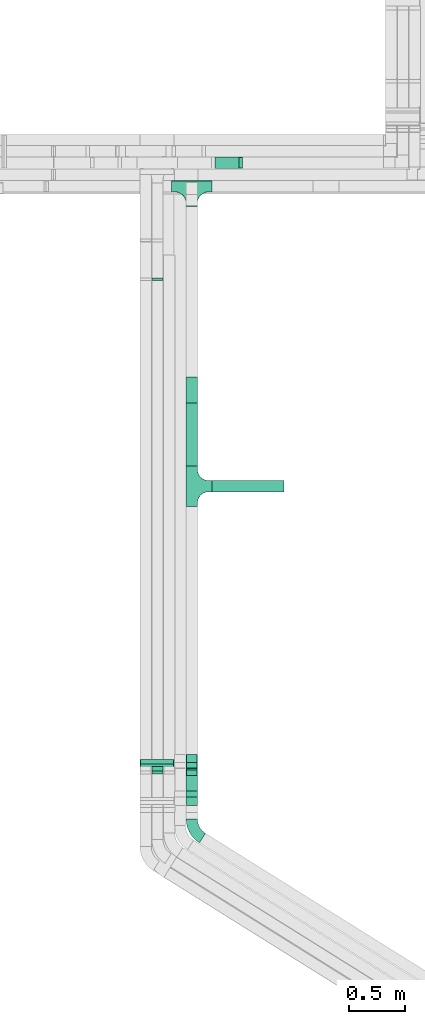
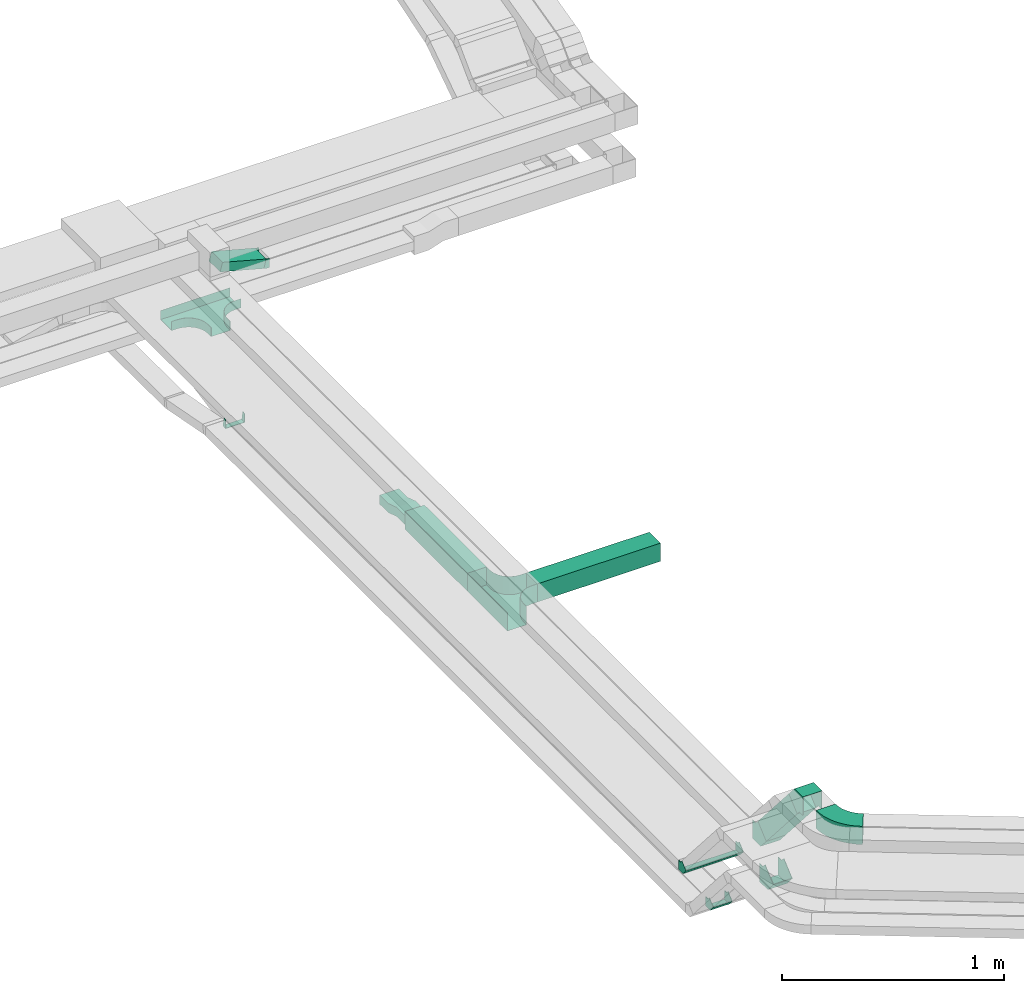
# One storey, part 5 of 18: 11 flow fittings, 4 flow segments.
"""IFC2X3 building model written with IfcOpenShell, lengths in millimetres."""

from ifc_helpers import new_model, entity, si_unit, converted_unit, derived_unit, direction, frame, frame_2d, origin, origin_2d_with_axis, place, context, subcontext, project, spatial, polyline, circle_curve, parameter, trimmed, segment, composite_curve, rectangle, outline, extrude, faceted_brep, source, transform, mapped, material, type_object, type_shapes, element, save


model = new_model("IFC2X3")

# Units and contexts
model_context = context("Model", 3, precision=0.01, world=origin(), true_north=direction((6.12303176911189e-17, 1.0)))
body_context = subcontext(model_context, "Body", "Model", "MODEL_VIEW")
ifc_project = project(units=[si_unit("LENGTHUNIT", "METRE", prefix="MILLI"), si_unit("AREAUNIT", "SQUARE_METRE"), si_unit("VOLUMEUNIT", "CUBIC_METRE"), converted_unit("PLANEANGLEUNIT", "DEGREE", entity("IfcRatioMeasure", 0.0174532925199433), si_unit("PLANEANGLEUNIT", "RADIAN"), dimensions=[0, 0, 0, 0, 0, 0, 0]), si_unit("MASSUNIT", "GRAM", prefix="KILO"), derived_unit("MASSDENSITYUNIT", [(si_unit("MASSUNIT", "GRAM", prefix="KILO"), 1), (si_unit("LENGTHUNIT", "METRE"), -3)]), derived_unit("MOMENTOFINERTIAUNIT", [(si_unit("LENGTHUNIT", "METRE"), 4)]), si_unit("TIMEUNIT", "SECOND"), si_unit("FREQUENCYUNIT", "HERTZ"), si_unit("THERMODYNAMICTEMPERATUREUNIT", "DEGREE_CELSIUS"), derived_unit("THERMALTRANSMITTANCEUNIT", [(si_unit("MASSUNIT", "GRAM", prefix="KILO"), 1), (si_unit("THERMODYNAMICTEMPERATUREUNIT", "KELVIN"), -1), (si_unit("TIMEUNIT", "SECOND"), -3)]), derived_unit("VOLUMETRICFLOWRATEUNIT", [(si_unit("LENGTHUNIT", "METRE"), 3), (si_unit("TIMEUNIT", "SECOND"), -1)]), derived_unit("MASSFLOWRATEUNIT", [(si_unit("MASSUNIT", "GRAM", prefix="KILO"), 1), (si_unit("TIMEUNIT", "SECOND"), -1)]), derived_unit("ROTATIONALFREQUENCYUNIT", [(si_unit("TIMEUNIT", "SECOND"), -1)]), si_unit("ELECTRICCURRENTUNIT", "AMPERE"), si_unit("ELECTRICVOLTAGEUNIT", "VOLT"), si_unit("POWERUNIT", "WATT"), si_unit("FORCEUNIT", "NEWTON", prefix="KILO"), si_unit("ILLUMINANCEUNIT", "LUX"), si_unit("LUMINOUSFLUXUNIT", "LUMEN"), si_unit("LUMINOUSINTENSITYUNIT", "CANDELA"), derived_unit("USERDEFINED", [(si_unit("MASSUNIT", "GRAM", prefix="KILO"), -1), (si_unit("LENGTHUNIT", "METRE"), -2), (si_unit("TIMEUNIT", "SECOND"), 3), (si_unit("LUMINOUSFLUXUNIT", "LUMEN"), 1)]), derived_unit("LINEARVELOCITYUNIT", [(si_unit("LENGTHUNIT", "METRE"), 1), (si_unit("TIMEUNIT", "SECOND"), -1)]), si_unit("PRESSUREUNIT", "PASCAL"), derived_unit("USERDEFINED", [(si_unit("LENGTHUNIT", "METRE"), -2), (si_unit("MASSUNIT", "GRAM", prefix="KILO"), 1), (si_unit("TIMEUNIT", "SECOND"), -2)]), derived_unit("LINEARFORCEUNIT", [(si_unit("MASSUNIT", "GRAM", prefix="KILO"), 1), (si_unit("LENGTHUNIT", "METRE"), 1), (si_unit("TIMEUNIT", "SECOND"), -2), (si_unit("LENGTHUNIT", "METRE"), -1)]), derived_unit("PLANARFORCEUNIT", [(si_unit("MASSUNIT", "GRAM", prefix="KILO"), 1), (si_unit("LENGTHUNIT", "METRE"), 1), (si_unit("TIMEUNIT", "SECOND"), -2), (si_unit("LENGTHUNIT", "METRE"), -2)])], contexts=[model_context])

# Site, building, storey
site_placement = place(None, frame((0.0, -0.00077364408347762, 0.0)))
site = spatial("IfcSite", under=ifc_project, at=site_placement, CompositionType="ELEMENT")
building_placement = place(site_placement, origin())
building = spatial("IfcBuilding", under=site, at=building_placement, CompositionType="ELEMENT")
storey_placement = place(building_placement, frame((0.0, 0.0, 19800.0)))
storey = spatial("IfcBuildingStorey", under=building, at=storey_placement, CompositionType="ELEMENT", Elevation=19800.0)

# Flow segments
cable_carrier_segment_type = type_object("IfcCableCarrierSegmentType", PredefinedType="CABLETRAYSEGMENT")
flow_segment_1_placement = place(storey_placement, frame((18417.1440474966, 4436.29916105319, 2857.08439840759)))
element("IfcFlowSegment", 1, at=flow_segment_1_placement, inside=storey, type_object=cable_carrier_segment_type, context=body_context, shape_type="SweptSolid", body=[
    extrude(rectangle(XDim=99.9999999999979, YDim=99.9999999999989, at=frame_2d((0.0, 2.16715534406831e-12), x_axis=(1.0, 0.0))), frame((50.0, 316.103085662772, 32.8029514495245), z_axis=(0.0, -0.656059028990503, 0.754709580222776), x_axis=(0.0, 0.754709580222776, 0.656059028990503)), (0.0, 0.0, 1.0), 424.302683677666),
])
flow_segment_2_placement = place(storey_placement, frame((18647.1440474966, 7173.7507068651, 2600.0)))
element("IfcFlowSegment", 2, at=flow_segment_2_placement, inside=storey, type_object=cable_carrier_segment_type, context=body_context, shape_type="SweptSolid", body=[
    extrude(rectangle(XDim=640.000000000004, YDim=100.000000000001, at=frame_2d((-1.08002495835535e-12, 0.0), x_axis=(1.0, 0.0))), frame((320.0, 50.0, 0.0)), (0.0, 0.0, 1.0), 100.000000000003),
])
flow_segment_3_placement = place(storey_placement, frame((18417.1440474966, 7403.75070686511, 2600.0)))
element("IfcFlowSegment", 3, at=flow_segment_3_placement, inside=storey, type_object=cable_carrier_segment_type, context=body_context, shape_type="SweptSolid", body=[
    extrude(rectangle(XDim=560.199844800006, YDim=99.9999999999989, at=frame_2d((-5.40012479177676e-13, 0.0), x_axis=(1.0, 0.0))), frame((50.0, 280.099922400005, 0.0), z_axis=(0.0, 0.0, 1.0), x_axis=(0.0, 1.0, 0.0)), (0.0, 0.0, 1.0), 100.000000000003),
])
flow_segment_4_placement = place(storey_placement, frame((18659.4293993652, 10049.8208448265, 2604.02002912242)))
element("IfcFlowSegment", 4, at=flow_segment_4_placement, inside=storey, type_object=cable_carrier_segment_type, context=body_context, shape_type="SweptSolid", body=[
    extrude(rectangle(XDim=49.9999999999963, YDim=99.9999999999989, at=origin_2d_with_axis()), frame((6.47047612756534, 50.0, 85.1047478246198), z_axis=(0.965925826289085, 0.0, -0.258819045102459), x_axis=(0.258819045102459, 0.0, 0.965925826289085)), (0.0, 0.0, 1.0), 235.518225265324),
])

# Flow fittings
ifc_material = material()
cable_carrier_fitting_type_1 = type_object("IfcCableCarrierFittingType", PredefinedType="NOTDEFINED", material=ifc_material)
shared_shape_1 = source(origin(), body_context, "Body", "Brep", [
    faceted_brep([(-30.0649440542927, -25.0, 50.0), (-30.0649440542926, 25.0, 50.0), (-30.0649440542926, 25.0, 47.4600000101635), (-30.0649440542927, -22.4600000101599, 47.4600000101635), (-30.0649440542927, -22.4600000101599, -47.4600000101565), (-30.0649440542926, 25.0, -47.4600000101565), (-30.0649440542926, 25.0, -50.0), (-30.0649440542927, -25.0, -50.0), (38.5921175084832, 6.28882558187459, 50.0), (38.5921175084832, 6.28882558187459, -50.0), (0.856638497343776, 39.091777031399, -50.0), (0.856638497343783, 39.091777031399, -47.4600000101565), (36.6751551823852, 7.95521550884487, -47.4600000101565), (36.6751551823852, 7.95521550884487, 47.4600000101635), (0.856638497343774, 39.091777031399, 47.4600000101635), (0.85663849734377, 39.091777031399, 50.0), (11.3931563883155, -25.0, 50.0), (-11.3931563883146, 25.0, 50.0), (-11.3931563883146, 25.0, 47.4600000101635), (10.2356117038927, -22.46000001016, 47.4600000101635), (10.2356117038927, -22.46000001016, -47.4600000101565), (-11.3931563883146, 25.0, -47.4600000101565), (-11.3931563883146, 25.0, -50.0), (11.3931563883153, -25.0, -50.0)], [[[0, 1, 2, 3, 4, 5, 6, 7]], [[8, 9, 10, 11, 12, 13, 14, 15]], [[1, 0, 16, 8, 15, 17]], [[2, 1, 17, 18]], [[3, 2, 18, 14, 13, 19]], [[4, 3, 19, 20]], [[5, 4, 20, 12, 11, 21]], [[6, 5, 21, 22]], [[7, 6, 22, 10, 9, 23]], [[0, 7, 23, 16]], [[18, 17, 15, 14]], [[20, 19, 13, 12]], [[22, 21, 11, 10]], [[16, 23, 9, 8]]]),
])
type_shapes(cable_carrier_fitting_type_1, [shared_shape_1])
flow_fitting_1_placement = place(storey_placement, frame((18162.1440474966, 4702.01853841968, 2625.0), z_axis=(1.0, 0.0, 0.0), x_axis=(0.0, 0.656059028990493, -0.754709580222785)))
element("IfcFlowFitting", 5, at=flow_fitting_1_placement, inside=storey, type_object=cable_carrier_fitting_type_1, material=ifc_material, context=body_context, shape_type="MappedRepresentation", body=[
    mapped(shared_shape_1, transform((0.0, 0.0, 0.0), scale=1.0)),
])
cable_carrier_fitting_type_2 = type_object("IfcCableCarrierFittingType", Name="470_DKC_S5_Variable Angle Elbow 0-45:-", PredefinedType="NOTDEFINED", material=ifc_material)
shared_shape_2 = source(origin(), body_context, "Body", "SweptSolid", [
    extrude(outline(composite_curve([segment(polyline([(-85.6872894317007, -97.2200856007192), (-84.6872894316995, -97.2200856007192)]), True, "CONTINUOUS"), segment(trimmed(circle_curve(frame_2d((-84.687289431702, 152.77991439928), x_axis=(0.0, -1.0)), 250.0), [parameter(0.0)], [parameter(57.9999999999999)], True, "PARAMETER"), True, "CONTINUOUS"), segment(polyline([(127.324734607405, 20.3000983409809), (127.854653871638, 21.1481464371369)]), True, "CONTINUOUS"), segment(polyline([(127.854653871638, 21.1481464371369), (43.0498442559958, 74.1400728604577)]), True, "CONTINUOUS"), segment(polyline([(43.0498442559958, 74.1400728604576), (42.5199249917623, 73.2920247643008)]), True, "CONTINUOUS"), segment(trimmed(circle_curve(frame_2d((-84.687289431702, 152.77991439928), x_axis=(0.0, -1.0)), 150.0), [parameter(0.0)], [parameter(57.9999999999999)], True, "PARAMETER"), False, "CONTINUOUS"), segment(polyline([(-84.6872894317004, 2.77991439928066), (-85.6872894317016, 2.77991439928066)]), True, "CONTINUOUS"), segment(polyline([(-85.6872894317016, 2.77991439928066), (-85.6872894317007, -97.2200856007192)]), True, "CONTINUOUS")], self_intersect=False)), frame((-26.1745208588432, 47.2200856007104, -50.0)), (0.0, 0.0, 1.0), 100.0),
])
type_shapes(cable_carrier_fitting_type_2, [shared_shape_2])
flow_fitting_2_placement = place(storey_placement, frame((18467.1440474966, 4154.30384329325, 3250.0), z_axis=(0.0, 0.0, 1.0), x_axis=(0.0, -1.0, 0.0)))
element("IfcFlowFitting", 6, at=flow_fitting_2_placement, inside=storey, type_object=cable_carrier_fitting_type_2, material=ifc_material, Name="470_DKC_S5_Variable Angle Elbow 0-45:-", ObjectType="470_DKC_S5_Variable Angle Elbow 0-45:-", context=body_context, shape_type="MappedRepresentation", body=[
    mapped(shared_shape_2, transform((0.0, 0.0, 0.0), scale=1.0)),
])
cable_carrier_fitting_type_3 = type_object("IfcCableCarrierFittingType", PredefinedType="NOTDEFINED", material=ifc_material)
shared_shape_3 = source(origin(), body_context, "Body", "Brep", [
    faceted_brep([(-52.8512568309224, -50.0, 50.0), (-52.851256830922, 50.0, 50.0), (-52.851256830922, 50.0, 47.4600000101635), (-52.8512568309224, -47.4600000101598, 47.4600000101635), (-52.8512568309224, -47.4600000101598, -47.4600000101565), (-52.851256830922, 50.0, -47.4600000101565), (-52.851256830922, 50.0, -50.0), (-52.8512568309224, -50.0, -50.0), (72.4090232485621, 7.08439840758769, 50.0), (72.4090232485621, 7.08439840758768, -50.0), (-3.06193477371679, 72.6903013066365, -50.0), (-3.06193477371682, 72.6903013066365, -47.4600000101565), (70.492060922464, 8.75078833455798, -47.4600000101565), (70.4920609224641, 8.75078833455797, 47.4600000101635), (-3.06193477371679, 72.6903013066365, 47.4600000101635), (-3.06193477371679, 72.6903013066365, 50.0), (22.7863127766305, -50.0, 50.0), (-22.7863127766296, 50.0, 50.0), (-22.7863127766296, 50.0, 47.4600000101635), (21.6287680922077, -47.4600000101601, 47.4600000101635), (21.6287680922077, -47.4600000101601, -47.4600000101565), (-22.7863127766296, 50.0, -47.4600000101565), (-22.7863127766296, 50.0, -50.0), (22.7863127766303, -50.0, -50.0)], [[[0, 1, 2, 3, 4, 5, 6, 7]], [[8, 9, 10, 11, 12, 13, 14, 15]], [[1, 0, 16, 8, 15, 17]], [[2, 1, 17, 18]], [[3, 2, 18, 14, 13, 19]], [[4, 3, 19, 20]], [[5, 4, 20, 12, 11, 21]], [[6, 5, 21, 22]], [[7, 6, 22, 10, 9, 23]], [[0, 7, 23, 16]], [[18, 17, 15, 14]], [[20, 19, 13, 12]], [[22, 21, 11, 10]], [[16, 23, 9, 8]]]),
])
type_shapes(cable_carrier_fitting_type_3, [shared_shape_3])
for number, where, z_axis, x_axis in (
    (7, (18467.1440474966, 4439.3610958269, 3250.0), (1.0, 0.0, 0.0), (0.0, -0.656059028990503, 0.754709580222776)),
    (8, (18467.1440474966, 4787.07579095338, 2850.0), (1.0, 0.0, 0.0), (0.0, 0.656059028990503, -0.754709580222776)),
    (9, (18467.1440474966, 4723.7507068651, 2650.0), (1.0, 0.0, 0.0), (0.0, 0.656059028990495, -0.754709580222783)),
):
    element("IfcFlowFitting", number, at=place(storey_placement, frame(where, z_axis=z_axis, x_axis=x_axis)), inside=storey, type_object=cable_carrier_fitting_type_3, material=ifc_material, context=body_context, shape_type="MappedRepresentation", body=[
        mapped(shared_shape_3, transform((0.0, 0.0, 0.0), scale=1.0)),
    ])
cable_carrier_fitting_type_4 = type_object("IfcCableCarrierFittingType", PredefinedType="NOTDEFINED", material=ifc_material)
shared_shape_4 = source(origin(), body_context, "Body", "Brep", [
    faceted_brep([(-30.0649440542933, -25.0, 150.0), (-30.0649440542931, 25.0, 150.0), (-30.0649440542931, 25.0, 147.460000010164), (-30.0649440542933, -22.4600000101599, 147.460000010164), (-30.0649440542933, -22.4600000101599, -147.460000010156), (-30.0649440542931, 25.0, -147.460000010156), (-30.0649440542931, 25.0, -150.0), (-30.0649440542933, -25.0, -150.0), (38.5921175084835, 6.28882558187574, 150.0), (38.5921175084835, 6.28882558187574, -150.0), (0.856638497343465, 39.0917770313994, -150.0), (0.856638497343465, 39.0917770313994, -147.460000010156), (36.6751551823854, 7.95521550884599, -147.460000010156), (36.6751551823854, 7.95521550884599, 147.460000010164), (0.856638497343467, 39.0917770313994, 147.460000010164), (0.856638497343465, 39.0917770313994, 150.0), (11.3931563883158, -25.0, 150.0), (-11.3931563883149, 25.0, 150.0), (-11.3931563883149, 25.0, 147.460000010164), (10.2356117038929, -22.46000001016, 147.460000010164), (10.235611703893, -22.46000001016, -147.460000010156), (-11.3931563883149, 25.0, -147.460000010156), (-11.3931563883149, 25.0, -150.0), (11.3931563883156, -25.0, -150.0)], [[[0, 1, 2, 3, 4, 5, 6, 7]], [[8, 9, 10, 11, 12, 13, 14, 15]], [[1, 0, 16, 8, 15, 17]], [[2, 1, 17, 18]], [[3, 2, 18, 14, 13, 19]], [[4, 3, 19, 20]], [[5, 4, 20, 12, 11, 21]], [[6, 5, 21, 22]], [[7, 6, 22, 10, 9, 23]], [[0, 7, 23, 16]], [[18, 17, 15, 14]], [[20, 19, 13, 12]], [[22, 21, 11, 10]], [[16, 23, 9, 8]]]),
])
type_shapes(cable_carrier_fitting_type_4, [shared_shape_4])
flow_fitting_3_placement = place(storey_placement, frame((18157.1440474966, 4765.34362250797, 2825.0), z_axis=(1.0, 0.0, 0.0), x_axis=(0.0, 0.656059028990504, -0.754709580222775)))
element("IfcFlowFitting", 10, at=flow_fitting_3_placement, inside=storey, type_object=cable_carrier_fitting_type_4, material=ifc_material, context=body_context, shape_type="MappedRepresentation", body=[
    mapped(shared_shape_4, transform((0.0, 0.0, 0.0), scale=1.0)),
])
cable_carrier_fitting_type_5 = type_object("IfcCableCarrierFittingType", PredefinedType="NOTDEFINED", material=ifc_material)
shared_shape_5 = source(origin(), body_context, "Body", "Brep", [
    faceted_brep([(-53.4074173710859, -124.118095489752, 25.0), (-50.0, -150.0, 25.0), (-50.0, -180.0, 25.0), (-49.1999999999934, -180.0, 25.0), (-49.1999999999926, -150.0, 25.0), (-52.6346767100545, -123.91104025367, 25.0), (-62.7046392985216, -99.6000000000037, 25.0), (-78.7236364563899, -78.7236364563991, 25.0), (-99.5999999999949, -62.7046392985315, 25.0), (-123.911040253662, -52.6346767100651, 25.0), (-150.0, -49.2000000000047, 25.0), (-180.0, -49.2000000000047, 25.0), (-180.0, -50.0, 25.0), (-150.0, -50.0, 25.0), (-124.118095489745, -53.4074173710983, 25.0), (-100.0, -63.3974596215602, 25.0), (-79.2893218813398, -79.2893218813488, 25.0), (-63.3974596215496, -100.0, 25.0), (180.0, -50.0, 25.0), (180.0, -49.2000000000047, 25.0), (150.0, -49.2000000000046, 25.0), (123.911040253717, -52.634676710066, 25.0), (99.6000000000452, -62.7046392985316, 25.0), (78.7236364564342, -78.7236364563979, 25.0), (62.7046392985581, -99.6000000000012, 25.0), (52.6346767100809, -123.911040253668, 25.0), (49.200000000007, -150.0, 25.0), (49.2000000000071, -180.0, 25.0), (50.0, -180.0, 25.0), (50.0, -150.0, 25.0), (53.4074173711136, -124.11809548975, 25.0), (63.3974596215874, -100.0, 25.0), (79.2893218813853, -79.2893218813486, 25.0), (100.0, -63.3974596215613, 25.0), (124.1180954898, -53.4074173710999, 25.0), (150.0, -50.0, 25.0), (180.0, 49.1999999999958, 25.0), (180.0, 50.0, 25.0), (-180.0, 50.0, 25.0), (-180.0, 49.1999999999958, 25.0), (-180.0, -50.0, -25.0), (-180.0, 50.0, -25.0), (180.0, 50.0, -25.0), (180.0, -50.0, -25.0), (150.0, -50.0, -25.0), (124.1180954898, -53.4074173710999, -25.0), (100.0, -63.3974596215613, -25.0), (79.2893218813853, -79.2893218813486, -25.0), (63.3974596215874, -100.0, -25.0), (53.4074173711136, -124.11809548975, -25.0), (50.0, -150.0, -25.0), (50.0, -180.0, -25.0), (-50.0, -180.0, -25.0), (-50.0, -150.0, -25.0), (-53.4074173710859, -124.118095489752, -25.0), (-63.3974596215496, -100.0, -25.0), (-79.2893218813398, -79.2893218813488, -25.0), (-100.0, -63.3974596215602, -25.0), (-124.118095489745, -53.4074173710983, -25.0), (-150.0, -50.0, -25.0), (-50.0, -150.0, -24.199999999986), (49.2000000000071, -180.0, -24.199999999986), (-49.1999999999934, -180.0, -24.199999999986), (-49.1999999999926, -150.0, -24.199999999986), (-150.0, -49.2000000000047, -24.199999999986), (-180.0, -49.2000000000047, -24.199999999986), (180.0, -49.2000000000047, -24.199999999986), (150.0, -49.2000000000047, -24.199999999986), (-180.0, 49.1999999999958, -24.199999999986), (-150.0, -50.0, -24.199999999986), (150.0, -50.0, -24.199999999986), (180.0, 49.1999999999958, -24.199999999986), (49.200000000007, -150.0, -24.199999999986), (50.0, -150.0, -24.199999999986), (-123.911040253662, -52.6346767100651, -24.199999999986), (-99.5999999999949, -62.7046392985315, -24.199999999986), (-78.7236364563899, -78.7236364563991, -24.199999999986), (-62.7046392985217, -99.6000000000036, -24.199999999986), (-52.6346767100546, -123.91104025367, -24.199999999986), (52.6346767100807, -123.911040253669, -24.199999999986), (62.7046392985577, -99.6000000000018, -24.199999999986), (78.7236364564338, -78.7236364563983, -24.199999999986), (99.6000000000446, -62.704639298532, -24.199999999986), (123.911040253716, -52.6346767100662, -24.199999999986)], [[[0, 1, 2, 3, 4, 5, 6, 7, 8, 9, 10, 11, 12, 13, 14, 15, 16, 17]], [[18, 19, 20, 21, 22, 23, 24, 25, 26, 27, 28, 29, 30, 31, 32, 33, 34, 35]], [[36, 37, 38, 39]], [[40, 41, 42, 43, 44, 45, 46, 47, 48, 49, 50, 51, 52, 53, 54, 55, 56, 57, 58, 59]], [[2, 1, 60, 53, 52]], [[3, 2, 52, 51, 28, 27, 61, 62]], [[4, 3, 62, 63]], [[11, 10, 64, 65]], [[20, 19, 66, 67]], [[39, 38, 41, 40, 12, 11, 65, 68]], [[13, 12, 40, 59, 69]], [[18, 35, 70, 44, 43]], [[19, 18, 43, 42, 37, 36, 71, 66]], [[27, 26, 72, 61]], [[29, 28, 51, 50, 73]], [[38, 37, 42, 41]], [[36, 39, 68, 71]], [[68, 65, 64, 74, 75, 76, 77, 78, 63, 62, 61, 72, 79, 80, 81, 82, 83, 67, 66, 71]], [[14, 13, 69, 59, 58]], [[58, 57, 15, 14]], [[15, 57, 56, 16]], [[0, 17, 55, 54]], [[0, 54, 53, 60, 1]], [[55, 17, 16, 56]], [[5, 4, 63, 78]], [[6, 5, 78, 77]], [[7, 6, 77, 76]], [[8, 7, 76, 75]], [[9, 8, 75, 74]], [[10, 9, 74, 64]], [[21, 20, 67, 83]], [[22, 21, 83, 82]], [[23, 22, 82, 81]], [[81, 80, 24, 23]], [[24, 80, 79, 25]], [[79, 72, 26, 25]], [[30, 29, 73, 50, 49]], [[31, 30, 49, 48]], [[31, 48, 47, 32]], [[33, 32, 47, 46]], [[45, 34, 33, 46]], [[34, 45, 44, 70, 35]]]),
])
type_shapes(cable_carrier_fitting_type_5, [shared_shape_5])
flow_fitting_4_placement = place(storey_placement, frame((18467.1440474966, 9890.22583236338, 2625.0)))
element("IfcFlowFitting", 11, at=flow_fitting_4_placement, inside=storey, type_object=cable_carrier_fitting_type_5, material=ifc_material, Name="470_DKC_S5_T", context=body_context, shape_type="MappedRepresentation", body=[
    mapped(shared_shape_5, transform((0.0, 0.0, 0.0), scale=1.0)),
])
cable_carrier_fitting_type_6 = type_object("IfcCableCarrierFittingType", PredefinedType="NOTDEFINED", material=ifc_material)
shared_shape_6 = source(origin(), body_context, "Body", "Brep", [
    faceted_brep([(-53.4074173710859, -124.118095489752, 50.0), (-50.0, -150.0, 50.0), (-50.0, -180.0, 50.0), (-49.1999999999934, -180.0, 50.0), (-49.1999999999926, -150.0, 50.0), (-52.6346767100545, -123.91104025367, 50.0), (-62.7046392985216, -99.6000000000037, 50.0), (-78.7236364563899, -78.7236364563991, 50.0), (-99.5999999999949, -62.7046392985315, 50.0), (-123.911040253662, -52.6346767100651, 50.0), (-150.0, -49.2000000000047, 50.0), (-180.0, -49.2000000000047, 50.0), (-180.0, -50.0, 50.0), (-150.0, -50.0, 50.0), (-124.118095489745, -53.4074173710983, 50.0), (-100.0, -63.3974596215602, 50.0), (-79.2893218813398, -79.2893218813488, 50.0), (-63.3974596215496, -100.0, 50.0), (180.0, -50.0, 50.0), (180.0, -49.2000000000047, 50.0), (150.0, -49.2000000000046, 50.0), (123.911040253717, -52.634676710066, 50.0), (99.6000000000452, -62.7046392985316, 50.0), (78.7236364564342, -78.7236364563979, 50.0), (62.7046392985581, -99.6000000000012, 50.0), (52.6346767100809, -123.911040253668, 50.0), (49.200000000007, -150.0, 50.0), (49.2000000000071, -180.0, 50.0), (50.0, -180.0, 50.0), (50.0, -150.0, 50.0), (53.4074173711136, -124.11809548975, 50.0), (63.3974596215874, -100.0, 50.0), (79.2893218813853, -79.2893218813486, 50.0), (100.0, -63.3974596215613, 50.0), (124.1180954898, -53.4074173710999, 50.0), (150.0, -50.0, 50.0), (180.0, 49.1999999999958, 50.0), (180.0, 50.0, 50.0), (-180.0, 50.0, 50.0), (-180.0, 49.1999999999958, 50.0), (-180.0, -50.0, -50.0), (-180.0, 50.0, -50.0), (180.0, 50.0, -50.0), (180.0, -50.0, -50.0), (150.0, -50.0, -50.0), (124.1180954898, -53.4074173710999, -50.0), (100.0, -63.3974596215613, -50.0), (79.2893218813853, -79.2893218813486, -50.0), (63.3974596215874, -100.0, -50.0), (53.4074173711136, -124.11809548975, -50.0), (50.0, -150.0, -50.0), (50.0, -180.0, -50.0), (-50.0, -180.0, -50.0), (-50.0, -150.0, -50.0), (-53.4074173710859, -124.118095489752, -50.0), (-63.3974596215496, -100.0, -50.0), (-79.2893218813398, -79.2893218813488, -50.0), (-100.0, -63.3974596215602, -50.0), (-124.118095489745, -53.4074173710983, -50.0), (-150.0, -50.0, -50.0), (-50.0, -150.0, -49.1999999999851), (49.2000000000071, -180.0, -49.1999999999851), (-49.1999999999934, -180.0, -49.1999999999851), (-49.1999999999926, -150.0, -49.1999999999851), (-150.0, -49.2000000000047, -49.1999999999851), (-180.0, -49.2000000000047, -49.1999999999851), (180.0, -49.2000000000047, -49.1999999999851), (150.0, -49.2000000000047, -49.1999999999851), (-180.0, 49.1999999999958, -49.1999999999851), (-150.0, -50.0, -49.1999999999851), (150.0, -50.0, -49.1999999999851), (180.0, 49.1999999999958, -49.1999999999851), (49.200000000007, -150.0, -49.1999999999851), (50.0, -150.0, -49.1999999999851), (-123.911040253662, -52.6346767100651, -49.1999999999851), (-99.5999999999949, -62.7046392985315, -49.1999999999851), (-78.7236364563899, -78.7236364563991, -49.1999999999851), (-62.7046392985217, -99.6000000000036, -49.1999999999851), (-52.6346767100546, -123.91104025367, -49.1999999999851), (52.6346767100807, -123.911040253669, -49.1999999999851), (62.7046392985577, -99.6000000000018, -49.1999999999851), (78.7236364564338, -78.7236364563983, -49.1999999999851), (99.6000000000447, -62.7046392985319, -49.1999999999851), (123.911040253716, -52.6346767100662, -49.1999999999851)], [[[0, 1, 2, 3, 4, 5, 6, 7, 8, 9, 10, 11, 12, 13, 14, 15, 16, 17]], [[18, 19, 20, 21, 22, 23, 24, 25, 26, 27, 28, 29, 30, 31, 32, 33, 34, 35]], [[36, 37, 38, 39]], [[40, 41, 42, 43, 44, 45, 46, 47, 48, 49, 50, 51, 52, 53, 54, 55, 56, 57, 58, 59]], [[2, 1, 60, 53, 52]], [[3, 2, 52, 51, 28, 27, 61, 62]], [[4, 3, 62, 63]], [[11, 10, 64, 65]], [[20, 19, 66, 67]], [[39, 38, 41, 40, 12, 11, 65, 68]], [[13, 12, 40, 59, 69]], [[18, 35, 70, 44, 43]], [[19, 18, 43, 42, 37, 36, 71, 66]], [[27, 26, 72, 61]], [[29, 28, 51, 50, 73]], [[38, 37, 42, 41]], [[36, 39, 68, 71]], [[68, 65, 64, 74, 75, 76, 77, 78, 63, 62, 61, 72, 79, 80, 81, 82, 83, 67, 66, 71]], [[14, 13, 69, 59, 58]], [[15, 14, 58, 57]], [[57, 56, 16, 15]], [[17, 16, 56, 55]], [[0, 17, 55, 54]], [[1, 0, 54, 53, 60]], [[5, 78, 77, 6]], [[6, 77, 76, 7]], [[63, 78, 5, 4]], [[8, 75, 74, 9]], [[9, 74, 64, 10]], [[7, 76, 75, 8]], [[21, 83, 82, 22]], [[22, 82, 81, 23]], [[67, 83, 21, 20]], [[24, 80, 79, 25]], [[25, 79, 72, 26]], [[23, 81, 80, 24]], [[30, 29, 73, 50, 49]], [[31, 30, 49, 48]], [[32, 31, 48, 47]], [[34, 33, 46, 45]], [[34, 45, 44, 70, 35]], [[46, 33, 32, 47]]]),
])
type_shapes(cable_carrier_fitting_type_6, [shared_shape_6])
flow_fitting_5_placement = place(storey_placement, frame((18467.1440474966, 7223.7507068651, 2650.0), z_axis=(0.0, 0.0, 1.0), x_axis=(0.0, 1.0, 0.0)))
element("IfcFlowFitting", 12, at=flow_fitting_5_placement, inside=storey, type_object=cable_carrier_fitting_type_6, material=ifc_material, Name="470_DKC_S5_T", context=body_context, shape_type="MappedRepresentation", body=[
    mapped(shared_shape_6, transform((0.0, 0.0, 0.0), scale=1.0)),
])
cable_carrier_fitting_type_7 = type_object("IfcCableCarrierFittingType", PredefinedType="NOTDEFINED", material=ifc_material)
shared_shape_7 = source(origin(), body_context, "Body", "SweptSolid", [
    extrude(outline(polyline([(-115.0, 12.500000000005), (-115.0, -37.4999999999952), (-38.3333333333287, -37.4999999999952), (38.3333333333379, -12.5000000000313), (115.0, -12.4999999999965), (115.0, 37.5000000000037), (38.333333333326, 37.5000000000045), (-38.3333333333287, 12.500000000005), (-115.0, 12.500000000005)])), frame((115.0, -50.0, 12.4999999999943), z_axis=(0.0, -1.0, 0.0), x_axis=(1.0, 0.0, 0.0)), (0.0, 0.0, -1.0), 99.9999999999999),
])
type_shapes(cable_carrier_fitting_type_7, [shared_shape_7])
flow_fitting_6_placement = place(storey_placement, frame((18467.1440474966, 8193.95055166511, 2625.0), z_axis=(0.0, 0.0, 1.0), x_axis=(0.0, -1.0, 0.0)))
element("IfcFlowFitting", 13, at=flow_fitting_6_placement, inside=storey, type_object=cable_carrier_fitting_type_7, material=ifc_material, Name="470_DKC_S5_adapter", context=body_context, shape_type="MappedRepresentation", body=[
    mapped(shared_shape_7, transform((0.0, 0.0, 0.0), scale=1.0)),
])
cable_carrier_fitting_type_8 = type_object("IfcCableCarrierFittingType", PredefinedType="NOTDEFINED", material=ifc_material)
shared_shape_8 = source(origin(), body_context, "Body", "Brep", [
    faceted_brep([(-12.2408873673373, -25.0, 50.0), (-12.2408873673371, 25.0, 50.0), (-12.2408873673371, 25.0, 47.4600000101635), (-12.2408873673373, -22.46000001016, 47.4600000101635), (-12.2408873673373, -22.46000001016, -47.4600000101565), (-12.2408873673371, 25.0, -47.4600000101565), (-12.2408873673371, 25.0, -50.0), (-12.2408873673373, -25.0, -50.0), (18.2942653723936, -20.9799708775852, 50.0), (18.2942653723936, -20.9799708775852, -50.0), (5.35331311721434, 27.316320436854, -50.0), (5.35331311721434, 27.316320436854, -47.4600000101565), (17.6368650004601, -18.5265192886255, -47.4600000101565), (17.6368650004601, -18.5265192886255, 47.4600000101635), (5.35331311721434, 27.316320436854, 47.4600000101635), (5.35331311721434, 27.316320436854, 50.0), (3.29131243969929, -25.0, 50.0), (-3.29131243969851, 25.0, 50.0), (-3.29131243969851, 25.0, 47.4600000101635), (2.95691509716341, -22.46000001016, 47.4600000101635), (2.95691509716341, -22.46000001016, -47.4600000101565), (-3.29131243969851, 25.0, -47.4600000101565), (-3.29131243969851, 25.0, -50.0), (3.29131243969922, -25.0, -50.0)], [[[0, 1, 2, 3, 4, 5, 6, 7]], [[8, 9, 10, 11, 12, 13, 14, 15]], [[1, 0, 16, 8, 15, 17]], [[2, 1, 17, 18]], [[3, 2, 18, 14, 13, 19]], [[4, 3, 19, 20]], [[5, 4, 20, 12, 11, 21]], [[6, 5, 21, 22]], [[7, 6, 22, 10, 9, 23]], [[0, 7, 23, 16]], [[18, 17, 15, 14]], [[20, 19, 13, 12]], [[22, 21, 11, 10]], [[16, 23, 9, 8]]]),
])
type_shapes(cable_carrier_fitting_type_8, [shared_shape_8])
flow_fitting_7_placement = place(storey_placement, frame((18905.2168010831, 10099.8208448265, 2625.0), z_axis=(0.0, 1.0, 0.0), x_axis=(-1.0, 0.0, 0.0)))
element("IfcFlowFitting", 14, at=flow_fitting_7_placement, inside=storey, type_object=cable_carrier_fitting_type_8, material=ifc_material, context=body_context, shape_type="MappedRepresentation", body=[
    mapped(shared_shape_8, transform((0.0, 0.0, 0.0), scale=1.0)),
])
cable_carrier_fitting_type_9 = type_object("IfcCableCarrierFittingType", PredefinedType="NOTDEFINED", material=ifc_material)
shared_shape_9 = source(origin(), body_context, "Body", "Brep", [
    faceted_brep([(-10.2391378100429, -25.0, 50.0), (-10.2391378100427, 25.0, 50.0), (-10.2391378100427, 25.0, 47.4600000101635), (-10.2391378100429, -22.46000001016, 47.4600000101635), (-10.2391378100429, -22.46000001016, -47.4600000101565), (-10.2391378100427, 25.0, -47.4600000101565), (-10.2391378100427, 25.0, -50.0), (-10.2391378100429, -25.0, -50.0), (14.7750143051017, -22.6172256339527, 50.0), (14.7750143051017, -22.6172256339528, -50.0), (5.33496729310332, 26.4835433255173, -50.0), (5.33496729310332, 26.4835433255173, -47.4600000101565), (14.2954599188104, -20.122906580789, -47.4600000101565), (14.2954599188104, -20.122906580789, 47.4600000101635), (5.33496729310332, 26.4835433255173, 47.4600000101635), (5.33496729310332, 26.4835433255173, 50.0), (2.3814262772927, -25.0, 50.0), (-2.38142627729195, 25.0, 50.0), (-2.38142627729195, 25.0, 47.4600000101635), (2.13947336848757, -22.46000001016, 47.4600000101635), (2.13947336848757, -22.46000001016, -47.4600000101565), (-2.38142627729195, 25.0, -47.4600000101565), (-2.38142627729195, 25.0, -50.0), (2.38142627729265, -25.0, -50.0)], [[[0, 1, 2, 3, 4, 5, 6, 7]], [[8, 9, 10, 11, 12, 13, 14, 15]], [[1, 0, 16, 8, 15, 17]], [[2, 1, 17, 18]], [[3, 2, 18, 14, 13, 19]], [[4, 3, 19, 20]], [[5, 4, 20, 12, 11, 21]], [[6, 5, 21, 22]], [[7, 6, 22, 10, 9, 23]], [[0, 7, 23, 16]], [[18, 17, 15, 14]], [[20, 19, 13, 12]], [[22, 21, 11, 10]], [[16, 23, 9, 8]]]),
])
type_shapes(cable_carrier_fitting_type_9, [shared_shape_9])
flow_fitting_8_placement = place(storey_placement, frame((18162.1440474966, 9062.01853841962, 2625.0), z_axis=(1.0, 0.0, 0.0), x_axis=(0.0, 1.0, 0.0)))
element("IfcFlowFitting", 15, at=flow_fitting_8_placement, inside=storey, type_object=cable_carrier_fitting_type_9, material=ifc_material, context=body_context, shape_type="MappedRepresentation", body=[
    mapped(shared_shape_9, transform((0.0, 0.0, 0.0), scale=1.0)),
])

save(model, "model.ifc")
